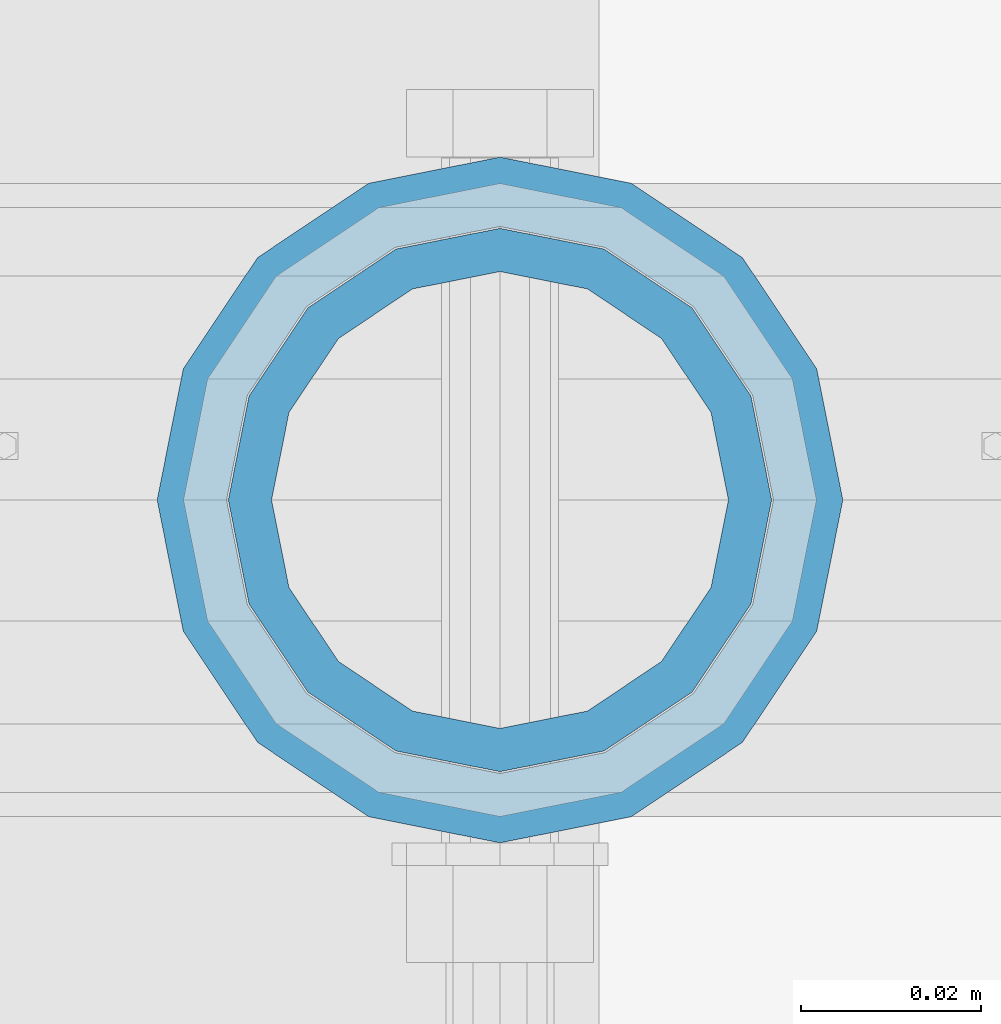
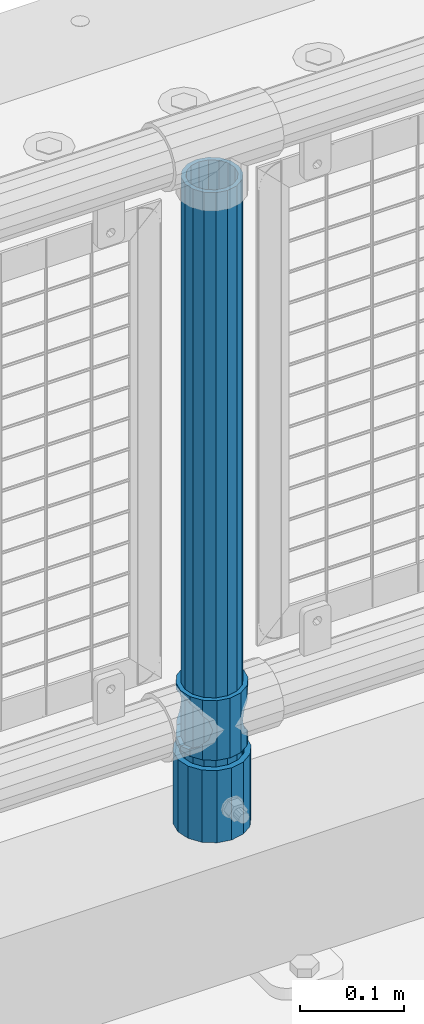
# One storey, part 100 of 270: 3 columns.
"""IFC2X3 building model written with IfcOpenShell, lengths in millimetres."""

import ifcopenshell
import ifcopenshell.guid

model = None  # the IFC model being written
_history = None  # IfcOwnerHistory: only IFC2X3 demands one
_inside = {}  # id of a spatial element -> (the spatial element, [elements in it])
_under = {}  # id of a project, library or spatial element -> (it, [spatial elements below it])
_declared = {}  # id of a project -> (the project, [libraries it declares])
_typed = {}  # id of a type object -> (the type object, [elements of that type])
_made_of = {}  # id of a material, layer set ... -> (it, [elements and type objects made of it])


def new_model(schema):
    """Start an empty IFC model of exactly this schema.

    Asked for "IFC4X3", IfcOpenShell would pick the latest addendum, in which some entities
    have other attributes; the version numbers below select the first issue.
    IFC2X3 requires an IfcOwnerHistory on every rooted entity: one is made here for all.
    """
    global model, _history
    if schema == "IFC4X3":
        model = ifcopenshell.file(schema_version=(4, 3, 0, 0))
    else:
        model = ifcopenshell.file(schema=schema)
    _inside.clear()
    _under.clear()
    _declared.clear()
    _typed.clear()
    _made_of.clear()
    _history = None
    if model.schema == "IFC2X3":
        org = make("IfcOrganization", Name="unknown")
        user = make(
            "IfcPersonAndOrganization",
            ThePerson=make("IfcPerson", FamilyName="unknown"),
            TheOrganization=org,
        )
        app = make(
            "IfcApplication",
            ApplicationDeveloper=org,
            Version="unknown",
            ApplicationFullName="unknown",
            ApplicationIdentifier="unknown",
        )
        _history = make(
            "IfcOwnerHistory",
            OwningUser=user,
            OwningApplication=app,
            ChangeAction="ADDED",
            CreationDate=0,
        )
    return model


def make(cls, **values):
    """One entity of the class cls with the attributes given. An attribute that is None is left unset."""
    return model.create_entity(
        cls, **{name: value for name, value in values.items() if value is not None}
    )


def rooted(cls, **values):
    """An entity with a GlobalId (a new one), such as an element, a storey or a relation."""
    return make(cls, GlobalId=ifcopenshell.guid.new(), OwnerHistory=_history, **values)


def si_unit(unit_type, name, prefix=None):
    """IfcSIUnit, for example si_unit("LENGTHUNIT", "METRE", prefix="MILLI")."""
    return make("IfcSIUnit", UnitType=unit_type, Prefix=prefix, Name=name)


def assignment(units):
    """IfcUnitAssignment: the units of a project."""
    return None if units is None else make("IfcUnitAssignment", Units=units)


def point(xyz):
    """IfcCartesianPoint."""
    return None if xyz is None else make("IfcCartesianPoint", Coordinates=xyz)


def direction(xyz):
    """IfcDirection."""
    return None if xyz is None else make("IfcDirection", DirectionRatios=xyz)


def frame(location, z_axis=None, x_axis=None):
    """IfcAxis2Placement3D, a coordinate frame: its origin and axes. An axis left out is left unset."""
    return make(
        "IfcAxis2Placement3D",
        Location=point(location),
        Axis=direction(z_axis),
        RefDirection=direction(x_axis),
    )


def origin_with_axes():
    """The frame at (0, 0, 0) with the z axis (0, 0, 1) and the x axis (1, 0, 0) written out."""
    return frame((0.0, 0.0, 0.0), z_axis=(0.0, 0.0, 1.0), x_axis=(1.0, 0.0, 0.0))


def place(relative_to, where):
    """IfcLocalPlacement: puts the frame where relative to a parent placement (None: the world)."""
    return make(
        "IfcLocalPlacement", PlacementRelTo=relative_to, RelativePlacement=where
    )


def context(
    kind, dimensions, precision=None, world=None, true_north=None, identifier=None
):
    """IfcGeometricRepresentationContext, for example the 3D "Model" context."""
    return make(
        "IfcGeometricRepresentationContext",
        ContextIdentifier=identifier,
        ContextType=kind,
        CoordinateSpaceDimension=dimensions,
        Precision=precision,
        WorldCoordinateSystem=world,
        TrueNorth=true_north,
    )


def subcontext(parent, identifier, kind, view, scale=None):
    """IfcGeometricRepresentationSubContext, for example "Body" below "Model"."""
    return make(
        "IfcGeometricRepresentationSubContext",
        ContextIdentifier=identifier,
        ContextType=kind,
        ParentContext=parent,
        TargetScale=scale,
        TargetView=view,
    )


def project(units=None, contexts=None):
    """IfcProject with its units and contexts."""
    return rooted(
        "IfcProject",
        Name="project",
        RepresentationContexts=contexts,
        UnitsInContext=assignment(units),
    )


def spatial(cls, under=None, at=None, **own):
    """A site, building, storey or space (cls), placed at a placement, below another one or the project."""
    s = rooted(cls, ObjectPlacement=at, **own)
    if under is not None:
        _under.setdefault(under.id(), (under, []))[1].append(s)
    return s


def faces_of(points, faces, orient=None, outer=None):
    """IfcFace entities. A face is a list of loops; a loop is a list of indices into points, from 0.

    orient and outer hold one flag for each loop. By default every Orientation is true, the
    first loop of a face is its IfcFaceOuterBound and the others are IfcFaceBound.
    """
    made = []
    for i, loops in enumerate(faces):
        bounds = []
        for j, loop in enumerate(loops):
            is_outer = j == 0 if outer is None else outer[i][j]
            bounds.append(
                make(
                    "IfcFaceOuterBound" if is_outer else "IfcFaceBound",
                    Bound=make("IfcPolyLoop", Polygon=[points[k] for k in loop]),
                    Orientation=True if orient is None else orient[i][j],
                )
            )
        made.append(make("IfcFace", Bounds=bounds))
    return made


def faceted_brep(points, faces, orient=None, outer=None, voids=None):
    """IfcFacetedBrep: a solid bounded by flat faces; with voids (closed shells), ...WithVoids."""
    shared = [point(p) for p in points]
    hull = make("IfcClosedShell", CfsFaces=faces_of(shared, faces, orient, outer))
    if voids is None:
        return make("IfcFacetedBrep", Outer=hull)
    return make(
        "IfcFacetedBrepWithVoids",
        Outer=hull,
        Voids=[
            make(cls, CfsFaces=faces_of(shared, fs, o, b)) for cls, fs, o, b in voids
        ],
    )


def shape(context_of_items, identifier, shape_type, items):
    """IfcShapeRepresentation: the items that make up one representation, for example the "Body"."""
    return make(
        "IfcShapeRepresentation",
        ContextOfItems=context_of_items,
        RepresentationIdentifier=identifier,
        RepresentationType=shape_type,
        Items=items,
    )


def material(Name=None, Category=None):
    """IfcMaterial."""
    return make("IfcMaterial", Name=Name, Category=Category)


def made_of(thing, what):
    """Note that an element or type object is made of a material, layer set ...; save() writes the relation."""
    if what is not None:
        _made_of.setdefault(what.id(), (what, []))[1].append(thing)
    return thing


def type_object(cls, material=None, **own):
    """A type object (cls), such as IfcWallType, which elements share."""
    return made_of(rooted(cls, **own), material)


def element(
    cls,
    number,
    at=None,
    inside=None,
    cuts=None,
    type_object=None,
    material=None,
    context=None,
    identifier="Body",
    shape_type=None,
    held_by="IfcProductDefinitionShape",
    body=None,
    shapes=None,
    **own,
):
    """One element of the class cls, such as IfcWall. Its Tag is "e" and its number.

    at: its placement. inside: the storey or other place that contains it. cuts: it is an
    opening in that element (IfcRelVoidsElement). A single representation is given by context,
    identifier, shape_type and body (its items); several are given by shapes. held_by: the class
    of the entity that holds the representations. save() writes the other relations.
    """
    e = rooted(cls, Tag="e%d" % number, ObjectPlacement=at, **own)
    if body is not None:
        shapes = [shape(context, identifier, shape_type, body)]
    if shapes is not None:
        e.Representation = make(held_by, Representations=shapes)
    if inside is not None:
        _inside.setdefault(inside.id(), (inside, []))[1].append(e)
    if cuts is not None:
        rooted(
            "IfcRelVoidsElement", RelatingBuildingElement=cuts, RelatedOpeningElement=e
        )
    if type_object is not None:
        _typed.setdefault(type_object.id(), (type_object, []))[1].append(e)
    return made_of(e, material)


def aggregate(whole, parts):
    """IfcRelAggregates: a whole, such as a stair, and the parts it consists of."""
    return rooted("IfcRelAggregates", RelatingObject=whole, RelatedObjects=parts)


def save(model, path):
    """Write the relations noted so far, then the file.

    IfcRelAggregates (storeys below a building ...), IfcRelContainedInSpatialStructure (elements
    in a storey), IfcRelDefinesByType, IfcRelAssociatesMaterial and IfcRelDeclares: one each for
    every whole, place, type object, material and project.
    """
    for whole, parts in _under.values():
        aggregate(whole, parts)
    for where, things in _inside.values():
        rooted(
            "IfcRelContainedInSpatialStructure",
            RelatedElements=things,
            RelatingStructure=where,
        )
    for kind, things in _typed.values():
        rooted("IfcRelDefinesByType", RelatedObjects=things, RelatingType=kind)
    for what, things in _made_of.values():
        rooted("IfcRelAssociatesMaterial", RelatedObjects=things, RelatingMaterial=what)
    for by, libraries in _declared.values():
        rooted("IfcRelDeclares", RelatingContext=by, RelatedDefinitions=libraries)
    model.write(path)


model = new_model("IFC2X3")

# Units and contexts
model_context = context("Model", 3, precision=1e-05, world=origin_with_axes())
body_context = subcontext(model_context, "Body", "Model", "MODEL_VIEW")
ifc_project = project(units=[si_unit("LENGTHUNIT", "METRE", prefix="MILLI"), si_unit("AREAUNIT", "SQUARE_METRE"), si_unit("VOLUMEUNIT", "CUBIC_METRE"), si_unit("MASSUNIT", "GRAM", prefix="KILO"), si_unit("TIMEUNIT", "SECOND"), si_unit("PLANEANGLEUNIT", "RADIAN"), si_unit("SOLIDANGLEUNIT", "STERADIAN"), si_unit("THERMODYNAMICTEMPERATUREUNIT", "DEGREE_CELSIUS"), si_unit("LUMINOUSINTENSITYUNIT", "LUMEN")], contexts=[model_context])

# Site, building, storey
site_placement = place(None, origin_with_axes())
site = spatial("IfcSite", under=ifc_project, at=site_placement, CompositionType="ELEMENT")
building_placement = place(site_placement, origin_with_axes())
building = spatial("IfcBuilding", under=site, at=building_placement, Name="Standard", CompositionType="ELEMENT")
storey_placement = place(building_placement, origin_with_axes())
storey = spatial("IfcBuildingStorey", under=building, at=storey_placement, Name="Undefined", CompositionType="ELEMENT", Elevation=0.0)

# Columns
ifc_material_1 = material()
column_type_1 = type_object("IfcColumnType", PredefinedType="NOTDEFINED")
column_1_placement = place(storey_placement, frame((15317.9999998042, -16335.5, 168.019999999998), z_axis=(-1.0, 0.0, 0.0), x_axis=(0.0, 0.0, 1.0)))
element("IfcColumn", 1, at=column_1_placement, inside=storey, type_object=column_type_1, material=ifc_material_1, context=body_context, shape_type="Brep", body=[
    faceted_brep([(0.0, -25.3500000000004, 0.0), (0.0, -23.4203461491616, 9.70102501045403), (760.0, -23.4203461491616, 9.70102501045403), (760.0, -25.3500000000004, 0.0), (0.0, -17.9251569030785, 17.9251569030785), (760.0, -17.9251569030785, 17.9251569030785), (0.0, -9.70102501045585, 23.4203461491597), (760.0, -9.70102501045585, 23.4203461491597), (0.0, 0.0, 25.3499999999985), (760.0, 0.0, 25.3499999999985), (0.0, 9.70102501045585, 23.4203461491597), (760.0, 9.70102501045585, 23.4203461491597), (0.0, 17.9251569030785, 17.9251569030785), (760.0, 17.9251569030785, 17.9251569030785), (0.0, 23.4203461491616, 9.70102501045403), (760.0, 23.4203461491616, 9.70102501045403), (0.0, 25.3500000000004, 0.0), (760.0, 25.3500000000004, 0.0), (0.0, 23.4203461491616, -9.70102501045403), (760.0, 23.4203461491616, -9.70102501045403), (0.0, 17.9251569030785, -17.9251569030785), (760.0, 17.9251569030785, -17.9251569030785), (0.0, 9.70102501045585, -23.4203461491597), (760.0, 9.70102501045585, -23.4203461491597), (0.0, 0.0, -25.3499999999985), (760.0, 0.0, -25.3499999999985), (0.0, -9.70102501045585, -23.4203461491597), (760.0, -9.70102501045585, -23.4203461491597), (0.0, -17.9251569030785, -17.9251569030785), (760.0, -17.9251569030785, -17.9251569030785), (0.0, -23.4203461491616, -9.70102501045403), (760.0, -23.4203461491616, -9.70102501045403), (0.0, -30.1499999999996, 0.0), (0.0, -27.8549679052157, -11.5379054858058), (760.0, -27.8549679052157, -11.5379054858058), (760.0, -30.1499999999996, 0.0), (0.0, -21.3192694527752, -21.3192694527752), (760.0, -21.3192694527752, -21.3192694527752), (0.0, -11.5379054858076, -27.8549679052157), (760.0, -11.5379054858076, -27.8549679052157), (0.0, 0.0, -30.1500000000015), (760.0, 0.0, -30.1500000000015), (0.0, 11.5379054858076, -27.8549679052157), (760.0, 11.5379054858076, -27.8549679052157), (0.0, 21.3192694527752, -21.3192694527752), (760.0, 21.3192694527752, -21.3192694527752), (0.0, 27.8549679052157, -11.5379054858058), (760.0, 27.8549679052157, -11.5379054858058), (0.0, 30.1499999999996, 0.0), (760.0, 30.1499999999996, 0.0), (0.0, 27.8549679052157, 11.5379054858058), (760.0, 27.8549679052157, 11.5379054858058), (0.0, 21.3192694527752, 21.3192694527752), (760.0, 21.3192694527752, 21.3192694527752), (0.0, 11.5379054858076, 27.8549679052157), (760.0, 11.5379054858076, 27.8549679052157), (0.0, 0.0, 30.1500000000015), (760.0, 0.0, 30.1500000000015), (0.0, -11.5379054858076, 27.8549679052157), (760.0, -11.5379054858076, 27.8549679052157), (0.0, -21.3192694527752, 21.3192694527752), (760.0, -21.3192694527752, 21.3192694527752), (0.0, -27.8549679052157, 11.5379054858058), (760.0, -27.8549679052157, 11.5379054858058)], [[[0, 1, 2, 3]], [[1, 4, 5, 2]], [[4, 6, 7, 5]], [[6, 8, 9, 7]], [[8, 10, 11, 9]], [[10, 12, 13, 11]], [[12, 14, 15, 13]], [[14, 16, 17, 15]], [[16, 18, 19, 17]], [[18, 20, 21, 19]], [[20, 22, 23, 21]], [[22, 24, 25, 23]], [[24, 26, 27, 25]], [[26, 28, 29, 27]], [[28, 30, 31, 29]], [[30, 0, 3, 31]], [[32, 33, 34, 35]], [[33, 36, 37, 34]], [[36, 38, 39, 37]], [[38, 40, 41, 39]], [[40, 42, 43, 41]], [[42, 44, 45, 43]], [[44, 46, 47, 45]], [[46, 48, 49, 47]], [[48, 50, 51, 49]], [[50, 52, 53, 51]], [[52, 54, 55, 53]], [[54, 56, 57, 55]], [[56, 58, 59, 57]], [[58, 60, 61, 59]], [[60, 62, 63, 61]], [[62, 32, 35, 63]], [[37, 39, 41, 43, 45, 47, 49, 51, 53, 55, 57, 59, 61, 63, 35, 34], [5, 7, 9, 11, 13, 15, 17, 19, 21, 23, 25, 27, 29, 31, 3, 2]], [[62, 60, 58, 56, 54, 52, 50, 48, 46, 44, 42, 40, 38, 36, 33, 32], [30, 28, 26, 24, 22, 20, 18, 16, 14, 12, 10, 8, 6, 4, 1, 0]]]),
])
column_type_2 = type_object("IfcColumnType", PredefinedType="NOTDEFINED")
column_2_placement = place(storey_placement, frame((15317.9999998042, -16335.5, 168.019999999998), z_axis=(0.0, 1.0, 0.0), x_axis=(0.0, 0.0, 1.0)))
element("IfcColumn", 2, at=column_2_placement, inside=storey, type_object=column_type_2, material=ifc_material_1, context=body_context, shape_type="Brep", body=[
    faceted_brep([(0.0, -31.75, 0.0), (0.0, -29.3331751572332, 12.1501989775916), (85.0, -29.3331751572332, 12.1501989775916), (85.0, -31.75, 0.0), (0.0, -22.4506403026717, 22.4506403026735), (85.0, -22.4506403026717, 22.4506403026735), (0.0, -12.1501989775934, 29.3331751572332), (85.0, -12.1501989775934, 29.3331751572332), (0.0, 0.0, 31.75), (85.0, 0.0, 31.75), (0.0, 12.1501989775934, 29.3331751572332), (85.0, 12.1501989775934, 29.3331751572332), (0.0, 22.4506403026717, 22.4506403026735), (85.0, 22.4506403026717, 22.4506403026735), (0.0, 29.3331751572332, 12.1501989775916), (85.0, 29.3331751572332, 12.1501989775916), (0.0, 31.75, 0.0), (85.0, 31.75, 0.0), (0.0, 29.3331751572332, -12.1501989775916), (85.0, 29.3331751572332, -12.1501989775916), (0.0, 22.4506403026717, -22.4506403026735), (85.0, 22.4506403026717, -22.4506403026735), (0.0, 12.1501989775934, -29.3331751572332), (85.0, 12.1501989775934, -29.3331751572332), (0.0, 0.0, -31.75), (85.0, 0.0, -31.75), (0.0, -12.1501989775934, -29.3331751572332), (85.0, -12.1501989775934, -29.3331751572332), (0.0, -22.4506403026717, -22.4506403026735), (85.0, -22.4506403026717, -22.4506403026735), (0.0, -29.3331751572332, -12.1501989775916), (85.0, -29.3331751572332, -12.1501989775916), (0.0, -38.0499999999993, 0.0), (0.0, -35.1536162120537, -14.561104601491), (85.0, -35.1536162120537, -14.561104601491), (85.0, -38.0499999999993, 0.0), (0.0, -26.9054130241493, -26.9054130241475), (85.0, -26.9054130241493, -26.9054130241475), (0.0, -14.5611046014928, -35.1536162120537), (85.0, -14.5611046014928, -35.1536162120537), (0.0, 0.0, -38.0499999999993), (85.0, 0.0, -38.0499999999993), (0.0, 14.5611046014928, -35.1536162120537), (85.0, 14.5611046014928, -35.1536162120537), (0.0, 26.9054130241493, -26.9054130241475), (85.0, 26.9054130241493, -26.9054130241475), (0.0, 35.1536162120537, -14.561104601491), (85.0, 35.1536162120537, -14.561104601491), (0.0, 38.0499999999993, 0.0), (85.0, 38.0499999999993, 0.0), (0.0, 35.1536162120537, 14.561104601491), (85.0, 35.1536162120537, 14.561104601491), (0.0, 26.9054130241493, 26.9054130241475), (85.0, 26.9054130241493, 26.9054130241475), (0.0, 14.5611046014928, 35.1536162120537), (85.0, 14.5611046014928, 35.1536162120537), (0.0, 0.0, 38.0499999999993), (85.0, 0.0, 38.0499999999993), (0.0, -14.5611046014928, 35.1536162120537), (85.0, -14.5611046014928, 35.1536162120537), (0.0, -26.9054130241493, 26.9054130241475), (85.0, -26.9054130241493, 26.9054130241475), (0.0, -35.1536162120537, 14.561104601491), (85.0, -35.1536162120537, 14.561104601491)], [[[0, 1, 2, 3]], [[1, 4, 5, 2]], [[4, 6, 7, 5]], [[6, 8, 9, 7]], [[8, 10, 11, 9]], [[10, 12, 13, 11]], [[12, 14, 15, 13]], [[14, 16, 17, 15]], [[16, 18, 19, 17]], [[18, 20, 21, 19]], [[20, 22, 23, 21]], [[22, 24, 25, 23]], [[24, 26, 27, 25]], [[26, 28, 29, 27]], [[28, 30, 31, 29]], [[30, 0, 3, 31]], [[32, 33, 34, 35]], [[33, 36, 37, 34]], [[36, 38, 39, 37]], [[38, 40, 41, 39]], [[40, 42, 43, 41]], [[42, 44, 45, 43]], [[44, 46, 47, 45]], [[46, 48, 49, 47]], [[48, 50, 51, 49]], [[50, 52, 53, 51]], [[52, 54, 55, 53]], [[54, 56, 57, 55]], [[56, 58, 59, 57]], [[58, 60, 61, 59]], [[60, 62, 63, 61]], [[62, 32, 35, 63]], [[37, 39, 41, 43, 45, 47, 49, 51, 53, 55, 57, 59, 61, 63, 35, 34], [5, 7, 9, 11, 13, 15, 17, 19, 21, 23, 25, 27, 29, 31, 3, 2]], [[62, 60, 58, 56, 54, 52, 50, 48, 46, 44, 42, 40, 38, 36, 33, 32], [30, 28, 26, 24, 22, 20, 18, 16, 14, 12, 10, 8, 6, 4, 1, 0]]]),
])
ifc_material_2 = material(Name="Misc_Undefined")
column_type_3 = type_object("IfcColumnType", PredefinedType="NOTDEFINED")
column_3_placement = place(storey_placement, frame((15318.0, -16335.5, 263.02), z_axis=(-1.0, 0.0, 0.0), x_axis=(0.0, 0.0, 1.0)))
element("IfcColumn", 3, at=column_3_placement, inside=storey, type_object=column_type_3, material=ifc_material_2, context=body_context, shape_type="Brep", body=[
    faceted_brep([(63.1897438117183, 11.6144421722802, -32.8397438117208), (63.1897438117183, 11.6144421722802, -28.0397438117179), (56.6106908090125, 21.4606908090118, -21.46069080901), (56.6106908090125, 21.4606908090118, -27.1226768591005), (61.9623795176767, 13.4513226476338, -32.4743655677703), (46.7644421722812, 28.0397438117179, -11.614442172282), (46.7644421722812, 28.0397438117179, -20.0882031229812), (51.5310424080071, 24.8548033587067, -24.8548033587067), (35.1500000000015, 30.35, 0.0), (35.1500000000008, 30.3500000000004, -16.6306603983612), (23.5355578277203, 28.0397438117179, -11.614442172282), (23.5355578277203, 28.0397438117179, -20.0882031229812), (18.7689575919954, 24.8548033587067, -24.8548033587067), (13.689309190989, 21.4606908090118, -21.46069080901), (13.689309190989, 21.4606908090118, -27.1226768591005), (8.33762048232484, 13.4513226476338, -32.4743655677703), (7.11025618828324, 11.6144421722802, -28.0397438117179), (7.11025618828324, 11.6144421722802, -32.8397438117208), (4.80000000000075, 0.0, -30.3499999999985), (4.80000000000075, 0.0, -35.1500000000015), (7.11025618828319, -11.6144421722802, -28.0397438117179), (7.11025618828319, -11.6144421722802, -32.8397438117172), (13.689309190989, -21.4606908090118, -21.46069080901), (13.689309190989, -21.4606908090118, -27.1226768591041), (8.33762048232484, -13.4513226476338, -32.4743655677703), (23.5355578277203, -28.0397438117179, -11.614442172282), (23.5355578277203, -28.0397438117179, -20.0882031229885), (18.7689575919954, -24.8548033587067, -24.8548033587067), (35.1500000000015, -30.35, 0.0), (35.1500000000008, -30.3500000000004, -16.6306603983721), (46.7644421722812, -28.0397438117179, -11.614442172282), (46.7644421722812, -28.0397438117179, -20.0882031229885), (51.5310424080071, -24.8548033587067, -24.8548033587067), (56.6106908090125, -21.4606908090118, -21.46069080901), (56.6106908090125, -21.4606908090118, -27.1226768591041), (61.9623795176767, -13.4513226476338, -32.4743655677703), (63.1897438117183, -11.6144421722802, -28.0397438117179), (63.1897438117183, -11.6144421722802, -32.8397438117172), (65.5000000000008, 0.0, -30.3499999999985), (65.5000000000008, 0.0, -35.1500000000015), (0.0, -28.0397438117179, -11.614442172282), (0.0, -30.3500000000004, 0.0), (0.0, -21.4606908090118, -21.46069080901), (0.0, -11.6144421722802, -28.0397438117179), (0.0, 0.0, -30.3499999999985), (0.0, 11.6144421722802, -28.0397438117179), (0.0, 21.4606908090118, -21.46069080901), (0.0, 28.0397438117179, -11.614442172282), (0.0, 30.3500000000004, 0.0), (0.0, 28.0397438117179, 11.614442172282), (23.5355578277192, 28.0397438117179, 11.614442172282), (0.0, 21.4606908090118, 21.46069080901), (13.6893091909879, 21.4606908090118, 21.46069080901), (0.0, 11.6144421722802, 28.0397438117179), (7.11025618828211, 11.6144421722802, 28.0397438117179), (0.0, 0.0, 30.3499999999985), (4.79999999999961, 0.0, 30.3499999999985), (0.0, -11.6144421722802, 28.0397438117179), (7.11025618828205, -11.6144421722802, 28.0397438117179), (0.0, -21.4606908090118, 21.46069080901), (13.6893091909879, -21.4606908090118, 21.46069080901), (0.0, -28.0397438117179, 11.614442172282), (23.5355578277191, -28.0397438117179, 11.614442172282), (0.0, -32.4743655677721, 13.4513226476338), (0.0, -35.1499999999996, 0.0), (70.2999999999993, -35.1499999999996, 0.0), (70.2999999999993, -32.4743655677721, 13.4513226476338), (0.0, 13.4513226476338, -32.4743655677703), (0.0, 24.8548033587067, -24.8548033587067), (0.0, 0.0, -35.1499999999996), (0.0, -13.4513226476338, -32.4743655677703), (0.0, -24.8548033587067, -24.8548033587067), (0.0, -24.8548033587067, 24.8548033587067), (0.0, -13.4513226476338, 32.4743655677703), (0.0, 0.0, 35.1499999999996), (0.0, 13.4513226476338, 32.4743655677703), (0.0, 24.8548033587067, 24.8548033587067), (0.0, 32.4743655677721, 13.4513226476338), (0.0, 35.1499999999996, 0.0), (0.0, 32.4743655677721, -13.4513226476338), (0.0, -32.4743655677721, -13.4513226476338), (70.2999999999993, 32.4743655677721, 13.4513226476338), (70.2999999999993, 35.1499999999996, 0.0), (70.2999999999993, 32.4743655677721, -13.4513226476338), (70.2999999999993, 24.8548033587067, -24.8548033587067), (70.2999999999993, 13.4513226476338, -32.4743655677703), (70.2999999999993, 0.0, -35.1500000000015), (70.2999999999993, -13.4513226476338, -32.4743655677703), (70.2999999999993, -24.8548033587067, -24.8548033587067), (70.2999999999993, -32.4743655677721, -13.4513226476338), (70.2999999999993, 28.0397438117179, 11.614442172282), (70.2999999999993, 21.4606908090118, 21.46069080901), (56.6106908090114, 21.4606908090118, 21.46069080901), (46.7644421722801, 28.0397438117179, 11.614442172282), (70.2999999999993, 11.6144421722802, 28.0397438117179), (63.1897438117172, 11.6144421722802, 28.0397438117179), (70.2999999999993, 0.0, 30.3499999999985), (65.4999999999997, 0.0, 30.3499999999985), (70.2999999999993, -11.6144421722802, 28.0397438117179), (63.1897438117172, -11.6144421722802, 28.0397438117179), (70.2999999999993, -21.4606908090118, 21.46069080901), (56.6106908090114, -21.4606908090118, 21.46069080901), (70.2999999999993, -28.0397438117179, 11.614442172282), (46.7644421722801, -28.0397438117179, 11.614442172282), (70.2999999999993, -11.6144421722802, -28.0397438117179), (70.2999999999993, 0.0, -30.3499999999985), (70.2999999999993, -21.4606908090118, -21.46069080901), (70.2999999999993, -28.0397438117179, -11.614442172282), (70.2999999999993, -30.3500000000004, 0.0), (70.2999999999993, 24.8548033587067, 24.8548033587067), (70.2999999999993, 13.4513226476338, 32.4743655677703), (70.2999999999993, 0.0, 35.1500000000015), (70.2999999999993, -13.4513226476338, 32.4743655677703), (70.2999999999993, -24.8548033587067, 24.8548033587067), (70.2999999999993, 30.3500000000004, 0.0), (70.2999999999993, 28.0397438117179, -11.614442172282), (70.2999999999993, 21.4606908090118, -21.46069080901), (70.2999999999993, 11.6144421722802, -28.0397438117179), (61.9623795176767, 13.4513226476338, 32.4743655677703), (51.5310424080039, 24.8548033587067, 24.8548033587067), (56.6106908090114, 21.4606908090118, 27.1226768591041), (65.4999999999997, 0.0, 35.1500000000015), (63.1897438117172, 11.6144421722802, 32.8397438117172), (63.1897438117172, -11.6144421722802, 32.8397438117172), (61.9623795176767, -13.4513226476338, 32.4743655677703), (56.6106908090114, -21.4606908090118, 27.1226768591077), (51.5310424080071, -24.8548033587067, 24.8548033587067), (18.7689575919954, -24.8548033587067, 24.8548033587067), (46.7644421722801, -28.0397438117179, 20.0882031229849), (35.1499999999996, -30.3500000000004, 16.6306603983649), (23.5355578277191, -28.0397438117179, 20.0882031229849), (8.33762048232262, -13.4513226476338, 32.4743655677703), (13.6893091909879, -21.4606908090118, 27.1226768591077), (4.79999999999961, 0.0, 35.1500000000015), (7.11025618828205, -11.6144421722802, 32.8397438117172), (7.11025618828211, 11.6144421722802, 32.8397438117172), (8.33762048232262, 13.4513226476338, 32.4743655677703), (13.6893091909879, 21.4606908090118, 27.1226768591041), (18.7689575919954, 24.8548033587067, 24.8548033587067), (23.5355578277192, 28.0397438117179, 20.0882031229885), (35.1499999999996, 30.3500000000004, 16.6306603983685), (46.7644421722801, 28.0397438117179, 20.0882031229885)], [[[0, 1, 2, 3, 4]], [[3, 2, 5, 6, 7]], [[6, 5, 8, 9]], [[9, 8, 10, 11]], [[12, 11, 10, 13, 14]], [[15, 14, 13, 16, 17]], [[17, 16, 18, 19]], [[19, 18, 20, 21]], [[21, 20, 22, 23, 24]], [[23, 22, 25, 26, 27]], [[26, 25, 28, 29]], [[29, 28, 30, 31]], [[32, 31, 30, 33, 34]], [[35, 34, 33, 36, 37]], [[37, 36, 38, 39]], [[39, 38, 1, 0]], [[40, 41, 28, 25]], [[42, 40, 25, 22]], [[43, 42, 22, 20]], [[44, 43, 20, 18]], [[45, 44, 18, 16]], [[46, 45, 16, 13]], [[47, 46, 13, 10]], [[48, 47, 10, 8]], [[49, 48, 8, 50]], [[51, 49, 50, 52]], [[53, 51, 52, 54]], [[55, 53, 54, 56]], [[57, 55, 56, 58]], [[59, 57, 58, 60]], [[61, 59, 60, 62]], [[41, 61, 62, 28]], [[63, 64, 65, 66]], [[67, 68, 12, 14, 15]], [[69, 67, 15, 17, 19]], [[24, 70, 69, 19, 21]], [[27, 71, 70, 24, 23]], [[63, 72, 73, 74, 75, 76, 77, 78, 79, 68, 67, 69, 70, 71, 80, 64], [40, 42, 43, 44, 45, 46, 47, 48, 49, 51, 53, 55, 57, 59, 61, 41]], [[78, 77, 81, 82]], [[79, 78, 82, 83]], [[68, 79, 83, 84, 7, 6, 9, 11, 12]], [[7, 84, 85, 4, 3]], [[4, 85, 86, 39, 0]], [[87, 88, 32, 34, 35]], [[86, 87, 35, 37, 39]], [[29, 31, 32, 88, 89, 80, 71, 27, 26]], [[64, 80, 89, 65]], [[90, 91, 92, 93]], [[91, 94, 95, 92]], [[94, 96, 97, 95]], [[96, 98, 99, 97]], [[98, 100, 101, 99]], [[100, 102, 103, 101]], [[104, 105, 38, 36]], [[106, 104, 36, 33]], [[107, 106, 33, 30]], [[108, 107, 30, 28]], [[102, 108, 28, 103]], [[88, 87, 86, 85, 84, 83, 82, 81, 109, 110, 111, 112, 113, 66, 65, 89], [100, 98, 96, 94, 91, 90, 114, 115, 116, 117, 105, 104, 106, 107, 108, 102]], [[118, 110, 109, 119, 120]], [[121, 111, 110, 118, 122]], [[112, 111, 121, 123, 124]], [[113, 112, 124, 125, 126]], [[127, 72, 63, 66, 113, 126, 128, 129, 130]], [[131, 73, 72, 127, 132]], [[133, 74, 73, 131, 134]], [[75, 74, 133, 135, 136]], [[76, 75, 136, 137, 138]], [[119, 109, 81, 77, 76, 138, 139, 140, 141]], [[92, 120, 119, 141, 93]], [[95, 122, 118, 120, 92]], [[97, 121, 122, 95]], [[99, 123, 121, 97]], [[101, 125, 124, 123, 99]], [[103, 128, 126, 125, 101]], [[28, 129, 128, 103]], [[62, 130, 129, 28]], [[60, 132, 127, 130, 62]], [[58, 134, 131, 132, 60]], [[56, 133, 134, 58]], [[54, 135, 133, 56]], [[52, 137, 136, 135, 54]], [[50, 139, 138, 137, 52]], [[8, 140, 139, 50]], [[93, 141, 140, 8]], [[114, 90, 93, 8]], [[115, 114, 8, 5]], [[116, 115, 5, 2]], [[117, 116, 2, 1]], [[105, 117, 1, 38]]]),
])

save(model, "model.ifc")
